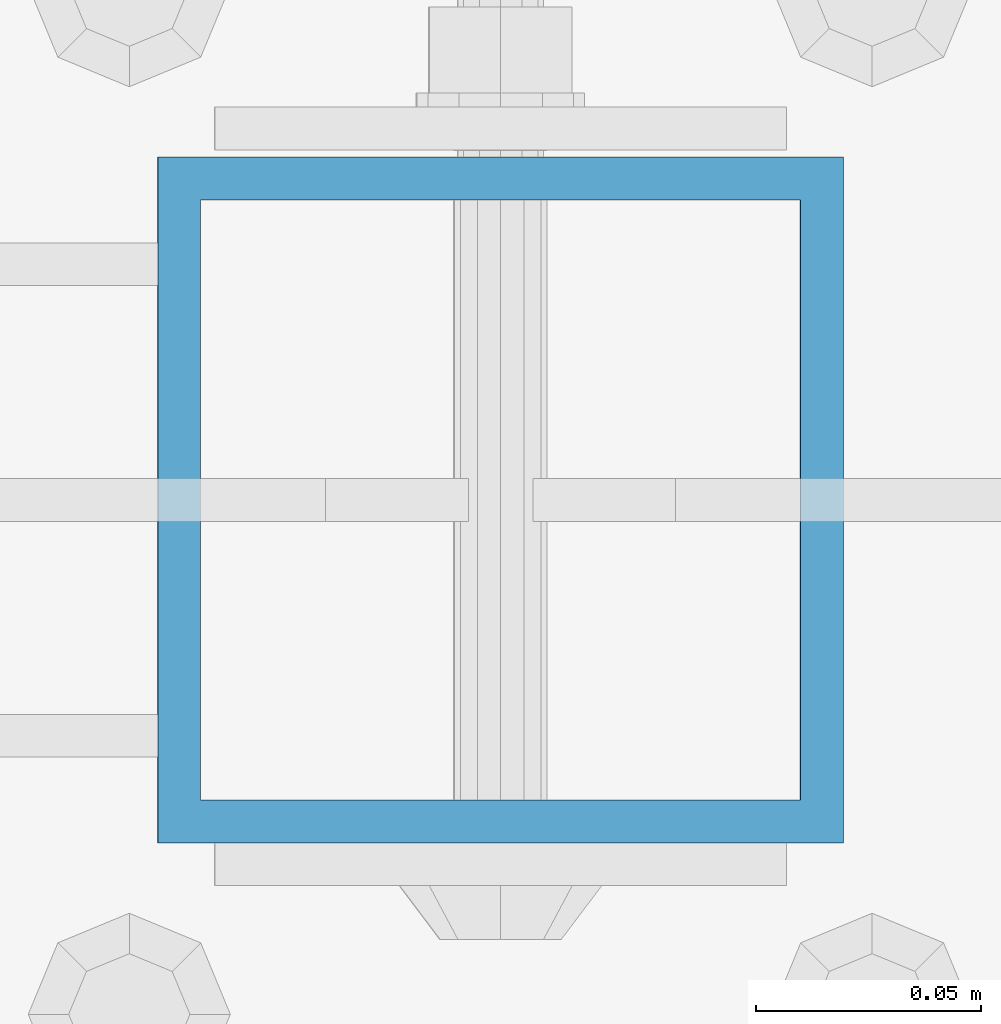
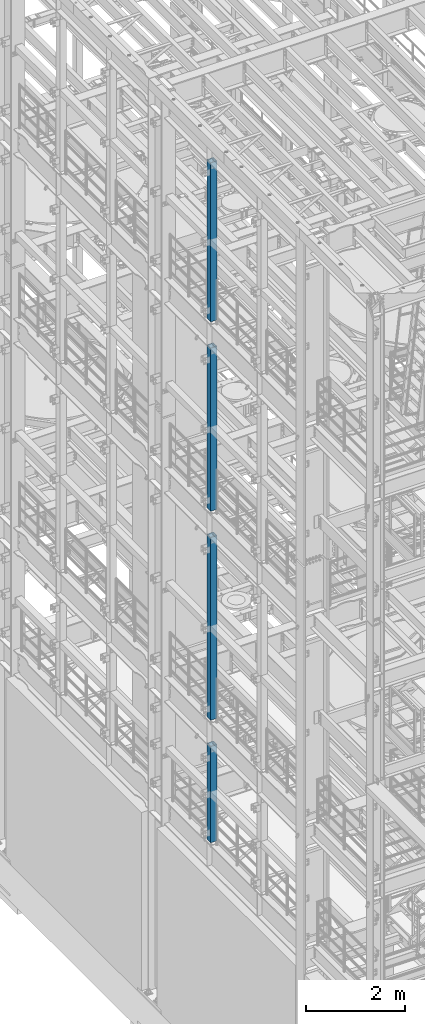
# One storey, part 680 of 1876: 4 columns, 4 elements without a shape of their own.
"""IFC2X3 building model written with IfcOpenShell, lengths in millimetres."""

from ifc_helpers import new_model, si_unit, frame, origin_with_axes, place, context, subcontext, project, spatial, faceted_brep, material, type_object, element, aggregate, save


model = new_model("IFC2X3")

# Units and contexts
model_context = context("Model", 3, precision=1e-05, world=origin_with_axes())
body_context = subcontext(model_context, "Body", "Model", "MODEL_VIEW")
ifc_project = project(units=[si_unit("LENGTHUNIT", "METRE", prefix="MILLI"), si_unit("AREAUNIT", "SQUARE_METRE"), si_unit("VOLUMEUNIT", "CUBIC_METRE"), si_unit("MASSUNIT", "GRAM", prefix="KILO"), si_unit("TIMEUNIT", "SECOND"), si_unit("PLANEANGLEUNIT", "RADIAN"), si_unit("SOLIDANGLEUNIT", "STERADIAN"), si_unit("THERMODYNAMICTEMPERATUREUNIT", "DEGREE_CELSIUS"), si_unit("LUMINOUSINTENSITYUNIT", "LUMEN")], contexts=[model_context])

# Site, building, storey
site_placement = place(None, origin_with_axes())
site = spatial("IfcSite", under=ifc_project, at=site_placement, CompositionType="ELEMENT")
building_placement = place(site_placement, origin_with_axes())
building = spatial("IfcBuilding", under=site, at=building_placement, Name="Undefined", CompositionType="ELEMENT")
storey_placement = place(building_placement, origin_with_axes())
storey = spatial("IfcBuildingStorey", under=building, at=storey_placement, Name="Undefined", CompositionType="ELEMENT", Elevation=0.0)

# Assembly, column
assembly_1_placement = place(storey_placement, origin_with_axes())
assembly_1 = element("IfcElementAssembly", 1, at=assembly_1_placement, inside=storey, Name="BEAM", AssemblyPlace="NOTDEFINED", PredefinedType="RIGID_FRAME")
ifc_material = material()
column_type = type_object("IfcColumnType", Name="HSS6X6X3/8", PredefinedType="NOTDEFINED")
column_1_placement = place(assembly_1_placement, frame((0.0, -508.000000000001, 17983.2), z_axis=(-1.0, 0.0, 0.0), x_axis=(0.0, 0.0, 1.0)))
column_1 = element("IfcColumn", 2, at=column_1_placement, type_object=column_type, material=ifc_material, Name="COLUMN", ObjectType="HSS6X6X3/8", context=body_context, shape_type="Brep", body=[
    faceted_brep([(12.7000000000016, 66.6750000000002, -66.6750000000002), (12.7000000000016, -66.6750000000002, -66.6750000000002), (3937.0, -66.6750000000002, -66.675), (3937.0, 66.6750000000002, -66.675), (12.7000000000016, -66.6750000000002, 66.6750000000002), (3937.0, -66.6750000000002, 66.675), (12.7000000000016, 66.6750000000002, 66.6750000000002), (3937.0, 66.6750000000002, 66.675), (12.7000000000016, 76.1999999999998, -76.1999999999998), (12.7000000000016, 76.1999999999998, 76.1999999999998), (3937.0, 76.1999999999998, 76.2), (3937.0, 76.1999999999998, -76.2), (12.7000000000016, -76.1999999999998, 76.1999999999998), (3937.0, -76.1999999999998, 76.2), (12.7000000000016, -76.1999999999998, -76.1999999999998), (3937.0, -76.1999999999998, -76.2)], [[[0, 1, 2, 3]], [[1, 4, 5, 2]], [[4, 6, 7, 5]], [[6, 0, 3, 7]], [[8, 9, 10, 11]], [[9, 12, 13, 10]], [[12, 14, 15, 13]], [[14, 8, 11, 15]], [[13, 15, 11, 10], [5, 7, 3, 2]], [[14, 12, 9, 8], [6, 4, 1, 0]]]),
])
aggregate(assembly_1, [column_1])

assembly_2_placement = place(storey_placement, origin_with_axes())
assembly_2 = element("IfcElementAssembly", 3, at=assembly_2_placement, inside=storey, Name="BEAM", AssemblyPlace="NOTDEFINED", PredefinedType="RIGID_FRAME")
column_2_placement = place(assembly_2_placement, frame((0.0, -508.000000000001, 13309.6), z_axis=(-1.0, 0.0, 0.0), x_axis=(0.0, 0.0, 1.0)))
column_2 = element("IfcColumn", 4, at=column_2_placement, type_object=column_type, material=ifc_material, Name="COLUMN", ObjectType="HSS6X6X3/8", context=body_context, shape_type="Brep", body=[
    faceted_brep([(12.7000000000016, 66.6750000000002, -66.6750000000002), (12.7000000000016, -66.6750000000002, -66.6750000000002), (4038.6, -66.6750000000002, -66.675), (4038.6, 66.6750000000002, -66.675), (12.7000000000016, -66.6750000000002, 66.6750000000002), (4038.6, -66.6750000000002, 66.675), (12.7000000000016, 66.6750000000002, 66.6750000000002), (4038.6, 66.6750000000002, 66.675), (12.7000000000016, 76.1999999999998, -76.1999999999998), (12.7000000000016, 76.1999999999998, 76.1999999999998), (4038.6, 76.1999999999998, 76.2), (4038.6, 76.1999999999998, -76.2), (12.7000000000016, -76.1999999999998, 76.1999999999998), (4038.6, -76.1999999999998, 76.2), (12.7000000000016, -76.1999999999998, -76.1999999999998), (4038.6, -76.1999999999998, -76.2)], [[[0, 1, 2, 3]], [[1, 4, 5, 2]], [[4, 6, 7, 5]], [[6, 0, 3, 7]], [[8, 9, 10, 11]], [[9, 12, 13, 10]], [[12, 14, 15, 13]], [[14, 8, 11, 15]], [[13, 15, 11, 10], [5, 7, 3, 2]], [[14, 12, 9, 8], [6, 4, 1, 0]]]),
])
aggregate(assembly_2, [column_2])

assembly_3_placement = place(storey_placement, origin_with_axes())
assembly_3 = element("IfcElementAssembly", 5, at=assembly_3_placement, inside=storey, Name="BEAM", AssemblyPlace="NOTDEFINED", PredefinedType="RIGID_FRAME")
column_3_placement = place(assembly_3_placement, frame((0.0, -508.000000000001, 8153.4), z_axis=(-0.999999999563517, 0.0, -2.95459999870218e-05), x_axis=(-2.95459999861759e-05, 0.0, 0.999999999563517)))
column_3 = element("IfcColumn", 6, at=column_3_placement, type_object=column_type, material=ifc_material, Name="COLUMN", ObjectType="HSS6X6X3/8", context=body_context, shape_type="Brep", body=[
    faceted_brep([(12.698030025992, 66.6750000000002, -66.675), (12.698030025992, -66.6750000000002, -66.675), (4521.2007045434, -66.6750000000002, -66.675), (4521.2007045434, 66.6750000000002, -66.675), (12.7019699850925, -66.6750000000002, 66.675), (4521.20070454334, -66.6750000000002, 66.675), (12.7019699850925, 66.6750000000002, 66.675), (4521.20070454334, 66.6750000000002, 66.675), (12.6977486003425, 76.1999999999998, -76.2), (12.7022514107421, 76.1999999999998, 76.2), (4521.20070454334, 76.1999999999998, 76.2), (4521.2007045434, 76.1999999999998, -76.2), (12.7022514107421, -76.1999999999998, 76.2), (4521.20070454334, -76.1999999999998, 76.2), (12.6977486003425, -76.1999999999998, -76.2), (4521.2007045434, -76.1999999999998, -76.2)], [[[0, 1, 2, 3]], [[1, 4, 5, 2]], [[4, 6, 7, 5]], [[6, 0, 3, 7]], [[8, 9, 10, 11]], [[9, 12, 13, 10]], [[12, 14, 15, 13]], [[14, 8, 11, 15]], [[13, 15, 11, 10], [5, 7, 3, 2]], [[14, 12, 9, 8], [6, 4, 1, 0]]]),
])
aggregate(assembly_3, [column_3])

assembly_4_placement = place(storey_placement, origin_with_axes())
assembly_4 = element("IfcElementAssembly", 7, at=assembly_4_placement, inside=storey, Name="BEAM", AssemblyPlace="NOTDEFINED", PredefinedType="RIGID_FRAME")
column_4_placement = place(assembly_4_placement, frame((0.0, -508.0, 5130.8), z_axis=(-0.999999998434855, 0.0, -5.59490000241567e-05), x_axis=(-5.59490000243298e-05, 0.0, 0.999999998434855)))
column_4 = element("IfcColumn", 8, at=column_4_placement, type_object=column_type, material=ifc_material, Name="COLUMN", ObjectType="HSS6X6X3/8", context=body_context, shape_type="Brep", body=[
    faceted_brep([(12.6962696202891, 66.6750000000002, -66.675), (12.6962696202891, -66.6750000000002, -66.675), (2387.60070630699, -66.6750000000002, -66.675), (2387.60070630699, 66.6750000000002, -66.675), (12.7037304194646, -66.6750000000002, 66.675), (2387.600706307, -66.6750000000002, 66.675), (12.7037304194646, 66.6750000000002, 66.675), (2387.600706307, 66.6750000000002, 66.675), (12.6957367060613, 76.1999999999998, -76.2), (12.7042633336914, 76.1999999999998, 76.2), (2387.600706307, 76.1999999999998, 76.2), (2387.60070630699, 76.1999999999998, -76.2), (12.7042633336914, -76.1999999999998, 76.2), (2387.600706307, -76.1999999999998, 76.2), (12.6957367060613, -76.1999999999998, -76.2), (2387.60070630699, -76.1999999999998, -76.2)], [[[0, 1, 2, 3]], [[1, 4, 5, 2]], [[4, 6, 7, 5]], [[6, 0, 3, 7]], [[8, 9, 10, 11]], [[9, 12, 13, 10]], [[12, 14, 15, 13]], [[14, 8, 11, 15]], [[13, 15, 11, 10], [5, 7, 3, 2]], [[14, 12, 9, 8], [6, 4, 1, 0]]]),
])
aggregate(assembly_4, [column_4])

save(model, "model.ifc")
